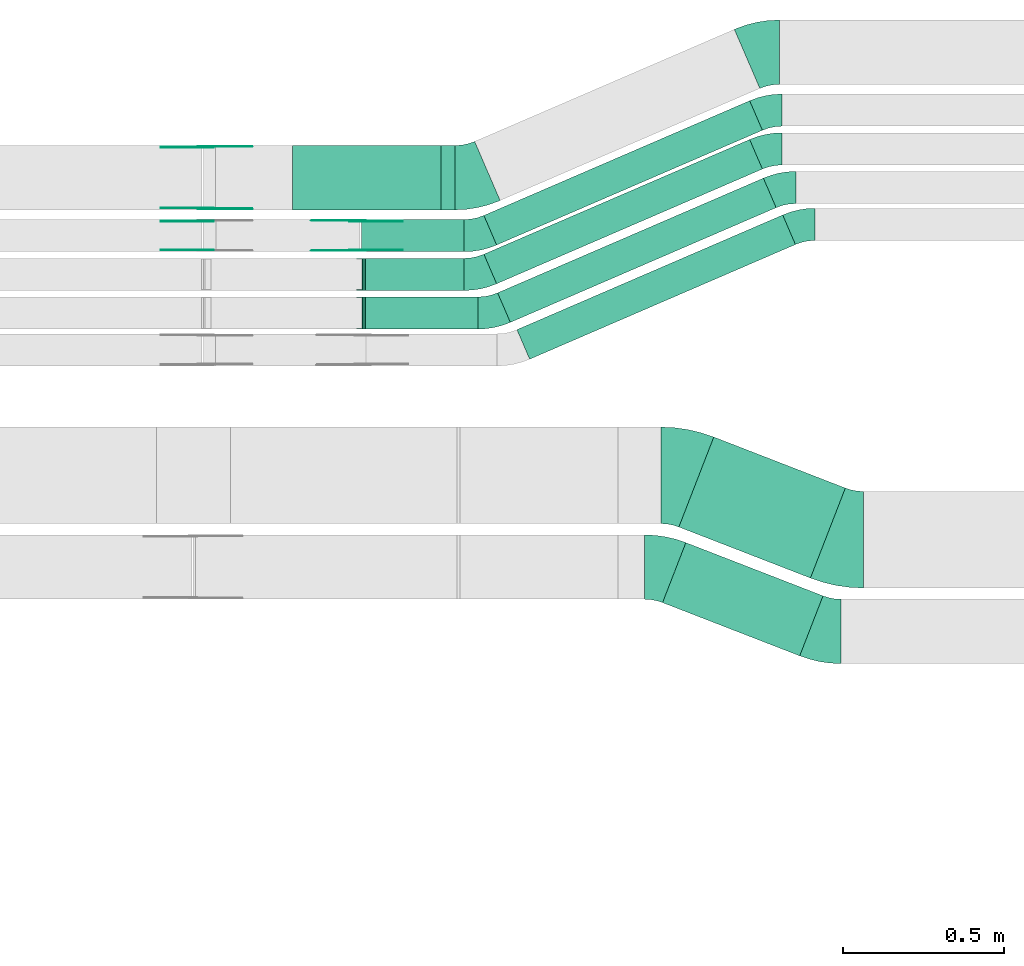
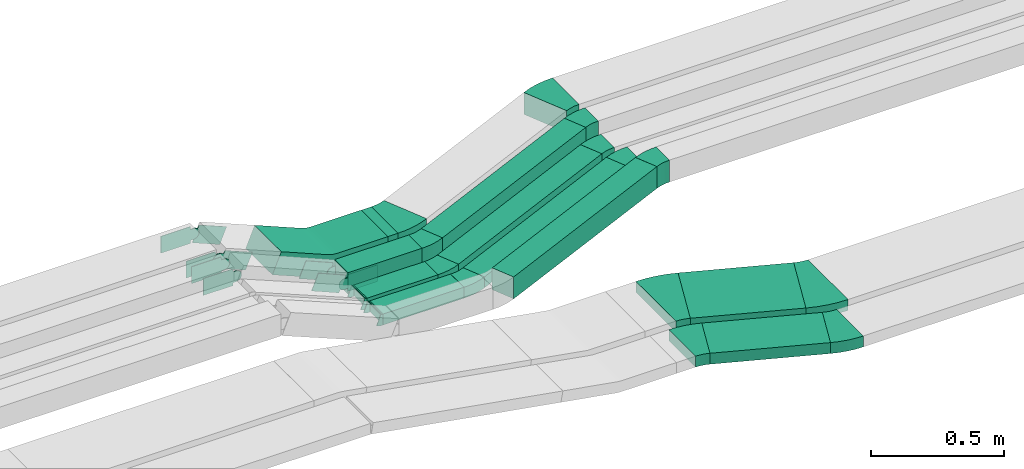
# One storey, part 16 of 28: 26 flow fittings, 10 flow segments.
"""IFC2X3 building model written with IfcOpenShell, lengths in millimetres."""

from ifc_helpers import new_model, entity, si_unit, converted_unit, derived_unit, direction, frame, frame_2d, origin, origin_2d_with_axis, place, context, subcontext, project, spatial, polyline, circle_curve, parameter, trimmed, segment, composite_curve, rectangle, outline, extrude, faceted_brep, source, transform, mapped, material, type_object, type_shapes, element, save


model = new_model("IFC2X3")

# Units and contexts
model_context = context("Model", 3, precision=0.01, world=origin(), true_north=direction((6.12303176911189e-17, 1.0)))
body_context = subcontext(model_context, "Body", "Model", "MODEL_VIEW")
ifc_project = project(units=[si_unit("LENGTHUNIT", "METRE", prefix="MILLI"), si_unit("AREAUNIT", "SQUARE_METRE"), si_unit("VOLUMEUNIT", "CUBIC_METRE"), converted_unit("PLANEANGLEUNIT", "DEGREE", entity("IfcRatioMeasure", 0.0174532925199433), si_unit("PLANEANGLEUNIT", "RADIAN"), dimensions=[0, 0, 0, 0, 0, 0, 0]), si_unit("MASSUNIT", "GRAM", prefix="KILO"), derived_unit("MASSDENSITYUNIT", [(si_unit("MASSUNIT", "GRAM", prefix="KILO"), 1), (si_unit("LENGTHUNIT", "METRE"), -3)]), derived_unit("MOMENTOFINERTIAUNIT", [(si_unit("LENGTHUNIT", "METRE"), 4)]), si_unit("TIMEUNIT", "SECOND"), si_unit("FREQUENCYUNIT", "HERTZ"), si_unit("THERMODYNAMICTEMPERATUREUNIT", "DEGREE_CELSIUS"), derived_unit("THERMALTRANSMITTANCEUNIT", [(si_unit("MASSUNIT", "GRAM", prefix="KILO"), 1), (si_unit("THERMODYNAMICTEMPERATUREUNIT", "KELVIN"), -1), (si_unit("TIMEUNIT", "SECOND"), -3)]), derived_unit("VOLUMETRICFLOWRATEUNIT", [(si_unit("LENGTHUNIT", "METRE"), 3), (si_unit("TIMEUNIT", "SECOND"), -1)]), derived_unit("MASSFLOWRATEUNIT", [(si_unit("MASSUNIT", "GRAM", prefix="KILO"), 1), (si_unit("TIMEUNIT", "SECOND"), -1)]), derived_unit("ROTATIONALFREQUENCYUNIT", [(si_unit("TIMEUNIT", "SECOND"), -1)]), si_unit("ELECTRICCURRENTUNIT", "AMPERE"), si_unit("ELECTRICVOLTAGEUNIT", "VOLT"), si_unit("POWERUNIT", "WATT"), si_unit("FORCEUNIT", "NEWTON", prefix="KILO"), si_unit("ILLUMINANCEUNIT", "LUX"), si_unit("LUMINOUSFLUXUNIT", "LUMEN"), si_unit("LUMINOUSINTENSITYUNIT", "CANDELA"), derived_unit("USERDEFINED", [(si_unit("MASSUNIT", "GRAM", prefix="KILO"), -1), (si_unit("LENGTHUNIT", "METRE"), -2), (si_unit("TIMEUNIT", "SECOND"), 3), (si_unit("LUMINOUSFLUXUNIT", "LUMEN"), 1)]), derived_unit("LINEARVELOCITYUNIT", [(si_unit("LENGTHUNIT", "METRE"), 1), (si_unit("TIMEUNIT", "SECOND"), -1)]), si_unit("PRESSUREUNIT", "PASCAL"), derived_unit("USERDEFINED", [(si_unit("LENGTHUNIT", "METRE"), -2), (si_unit("MASSUNIT", "GRAM", prefix="KILO"), 1), (si_unit("TIMEUNIT", "SECOND"), -2)]), derived_unit("LINEARFORCEUNIT", [(si_unit("MASSUNIT", "GRAM", prefix="KILO"), 1), (si_unit("LENGTHUNIT", "METRE"), 1), (si_unit("TIMEUNIT", "SECOND"), -2), (si_unit("LENGTHUNIT", "METRE"), -1)]), derived_unit("PLANARFORCEUNIT", [(si_unit("MASSUNIT", "GRAM", prefix="KILO"), 1), (si_unit("LENGTHUNIT", "METRE"), 1), (si_unit("TIMEUNIT", "SECOND"), -2), (si_unit("LENGTHUNIT", "METRE"), -2)])], contexts=[model_context])

# Site, building, storey
site_placement = place(None, origin())
site = spatial("IfcSite", under=ifc_project, at=site_placement, CompositionType="ELEMENT")
building_placement = place(site_placement, origin())
building = spatial("IfcBuilding", under=site, at=building_placement, CompositionType="ELEMENT")
storey_placement = place(building_placement, frame((0.0, 0.0, 15900.0)))
storey = spatial("IfcBuildingStorey", under=building, at=storey_placement, CompositionType="ELEMENT", Elevation=15900.0)

# Flow segments
cable_carrier_segment_type = type_object("IfcCableCarrierSegmentType", PredefinedType="CABLETRAYSEGMENT")
flow_segment_1_placement = place(storey_placement, frame((45925.0, 15609.99, 2635.0)))
element("IfcFlowSegment", 1, at=flow_segment_1_placement, inside=storey, type_object=cable_carrier_segment_type, context=body_context, shape_type="SweptSolid", body=[
    extrude(rectangle(XDim=43.6419436420277, YDim=199.999999999998, at=origin_2d_with_axis()), frame((21.82, 100.0, 0.0), z_axis=(0.0, 0.0, 1.0), x_axis=(-1.0, 0.0, 0.0)), (0.0, 0.0, 1.0), 99.9999999999989),
])
flow_segment_2_placement = place(storey_placement, frame((45677.85, 15479.99, 2635.0)))
element("IfcFlowSegment", 2, at=flow_segment_2_placement, inside=storey, type_object=cable_carrier_segment_type, context=body_context, shape_type="SweptSolid", body=[
    extrude(rectangle(XDim=319.463320328954, YDim=99.9999999999989, at=origin_2d_with_axis()), frame((159.73, 50.0, 0.0), z_axis=(0.0, 0.0, 1.0), x_axis=(-1.0, 0.0, 0.0)), (0.0, 0.0, 1.0), 100.000000000001),
])
flow_segment_3_placement = place(storey_placement, frame((45690.68, 15359.46, 2637.24)))
element("IfcFlowSegment", 3, at=flow_segment_3_placement, inside=storey, type_object=cable_carrier_segment_type, context=body_context, shape_type="SweptSolid", body=[
    extrude(rectangle(XDim=306.634255324862, YDim=99.9999999999989, at=origin_2d_with_axis()), frame((153.32, 50.0, 0.0), z_axis=(0.0, 0.0, 1.0), x_axis=(-1.0, 0.0, 0.0)), (0.0, 0.0, 1.0), 50.0000000000016),
])
flow_segment_4_placement = place(storey_placement, frame((45690.68, 15239.46, 2637.24)))
element("IfcFlowSegment", 4, at=flow_segment_4_placement, inside=storey, type_object=cable_carrier_segment_type, context=body_context, shape_type="SweptSolid", body=[
    extrude(rectangle(XDim=349.299577232627, YDim=99.9999999999989, at=origin_2d_with_axis()), frame((174.65, 50.0, 0.0)), (0.0, 0.0, 1.0), 50.0000000000016),
])
flow_segment_5_placement = place(storey_placement, frame((46664.57, 14465.87, 2650.0)))
element("IfcFlowSegment", 5, at=flow_segment_5_placement, inside=storey, type_object=cable_carrier_segment_type, context=body_context, shape_type="SweptSolid", body=[
    extrude(rectangle(XDim=438.486664288002, YDim=299.999999999994, at=origin_2d_with_axis()), frame((258.66, 219.16, 0.0), z_axis=(0.0, 0.0, 1.0), x_axis=(-0.932264171028324, 0.361778268303765, 0.0)), (0.0, 0.0, 1.0), 50.0000000000016),
])
flow_segment_6_placement = place(storey_placement, frame((46613.94, 14224.09, 2650.0)))
element("IfcFlowSegment", 6, at=flow_segment_6_placement, inside=storey, type_object=cable_carrier_segment_type, context=body_context, shape_type="SweptSolid", body=[
    extrude(rectangle(XDim=457.209687450545, YDim=200.000000000007, at=origin_2d_with_axis()), frame((249.3, 175.93, 0.0), z_axis=(0.0, 0.0, 1.0), x_axis=(0.932264171028315, -0.361778268303789, 0.0)), (0.0, 0.0, 1.0), 50.0000000000016),
])
flow_segment_7_placement = place(storey_placement, frame((46058.67, 15500.86, 2635.0)))
element("IfcFlowSegment", 7, at=flow_segment_7_placement, inside=storey, type_object=cable_carrier_segment_type, context=body_context, shape_type="SweptSolid", body=[
    extrude(rectangle(XDim=899.544928031288, YDim=100.000000000003, at=origin_2d_with_axis()), frame((432.77, 224.14, 0.0), z_axis=(0.0, 0.0, 1.0), x_axis=(-0.918134666973487, -0.396268511619942, 0.0)), (0.0, 0.0, 1.0), 99.9999999999989),
])
flow_segment_8_placement = place(storey_placement, frame((46058.67, 15380.32, 2637.24)))
element("IfcFlowSegment", 8, at=flow_segment_8_placement, inside=storey, type_object=cable_carrier_segment_type, context=body_context, shape_type="SweptSolid", body=[
    extrude(rectangle(XDim=899.544928031294, YDim=99.999999999988, at=origin_2d_with_axis()), frame((432.77, 224.14, 0.0), z_axis=(0.0, 0.0, 1.0), x_axis=(-0.9181346669735, -0.396268511619913, 0.0)), (0.0, 0.0, 1.0), 50.0000000000016),
])
flow_segment_9_placement = place(storey_placement, frame((46101.34, 15260.32, 2637.24)))
element("IfcFlowSegment", 9, at=flow_segment_9_placement, inside=storey, type_object=cable_carrier_segment_type, context=body_context, shape_type="SweptSolid", body=[
    extrude(rectangle(XDim=899.544928031396, YDim=99.999999999988, at=origin_2d_with_axis()), frame((432.77, 224.14, 0.0), z_axis=(0.0, 0.0, 1.0), x_axis=(-0.918134666973501, -0.396268511619909, 0.0)), (0.0, 0.0, 1.0), 50.0000000000016),
])
flow_segment_10_placement = place(storey_placement, frame((46161.34, 15145.86, 2634.95)))
element("IfcFlowSegment", 10, at=flow_segment_10_placement, inside=storey, type_object=cable_carrier_segment_type, context=body_context, shape_type="SweptSolid", body=[
    extrude(rectangle(XDim=899.544928031165, YDim=100.000000000003, at=origin_2d_with_axis()), frame((432.77, 224.14, 0.0), z_axis=(0.0, 0.0, 1.0), x_axis=(-0.918134666973488, -0.396268511619941, 0.0)), (0.0, 0.0, 1.0), 99.9999999999989),
])

# Flow fittings
ifc_material_1 = material()
cable_carrier_fitting_type_1 = type_object("IfcCableCarrierFittingType", PredefinedType="NOTDEFINED", material=ifc_material_1)
shared_shape_1 = source(origin(), body_context, "Body", "Brep", [
    faceted_brep([(-9.86, 25.0, 50.0), (-9.86, 25.0, -50.0), (-9.86, -25.0, -50.0), (-9.86, -25.0, -47.46), (-9.86, 22.46, -47.46), (-9.86, 22.46, 47.46), (-9.86, -25.0, 47.46), (-9.86, -25.0, 50.0), (-0.37, 26.87, 50.0), (18.62, -19.38, 50.0), (18.62, -19.38, 47.46), (0.6, 24.52, 47.46), (0.6, 24.52, -47.46), (18.62, -19.38, -47.46), (18.62, -19.38, -50.0), (-0.37, 26.87, -50.0), (-4.93, 25.0, 50.0), (-4.93, 25.0, -50.0), (4.93, -25.0, -50.0), (4.93, -25.0, -47.46), (-4.43, 22.46, -47.46), (-4.43, 22.46, 47.46), (4.93, -25.0, 47.46), (4.93, -25.0, 50.0)], [[[0, 1, 2, 3, 4, 5, 6, 7]], [[8, 9, 10, 11, 12, 13, 14, 15]], [[1, 0, 16, 17]], [[2, 1, 17, 15, 14, 18]], [[3, 2, 18, 19]], [[4, 3, 19, 13, 12, 20]], [[5, 4, 20, 21]], [[6, 5, 21, 11, 10, 22]], [[7, 6, 22, 23]], [[0, 7, 23, 9, 8, 16]], [[17, 16, 8, 15]], [[19, 18, 14, 13]], [[21, 20, 12, 11]], [[23, 22, 10, 9]]]),
])
type_shapes(cable_carrier_fitting_type_1, [shared_shape_1])
for number, where, z_axis, x_axis in (
    (11, (45680.82, 15409.46, 2662.24), (0.0, 1.0, 0.0), (-1.0, 0.0, 0.0)),
    (12, (45680.82, 15289.46, 2662.24), (0.0, -1.0, 0.0), (0.925113085294543, 0.0, -0.379691689949639)),
):
    element("IfcFlowFitting", number, at=place(storey_placement, frame(where, z_axis=z_axis, x_axis=x_axis)), inside=storey, type_object=cable_carrier_fitting_type_1, material=ifc_material_1, context=body_context, shape_type="MappedRepresentation", body=[
        mapped(shared_shape_1, transform((0.0, 0.0, 0.0), scale=1.0)),
    ])
ifc_material_2 = material(Name="G")
cable_carrier_fitting_type_2 = type_object("IfcCableCarrierFittingType", PredefinedType="NOTDEFINED", material=ifc_material_2)
shared_shape_2 = source(origin(), body_context, "Body", "SweptSolid", [
    extrude(outline(composite_curve([segment(trimmed(circle_curve(frame_2d((-41.47, 0.0), x_axis=(1.0, 0.0)), 25.0), [parameter(90.0000000000007)], [parameter(270.0)], True, "PARAMETER"), True, "CONTINUOUS"), segment(polyline([(-41.47, -25.0), (-29.97, -25.0)]), True, "CONTINUOUS"), segment(polyline([(-29.97, -25.0), (-28.1, -38.5)]), True, "CONTINUOUS"), segment(polyline([(-28.1, -38.5), (99.53, -38.5)]), True, "CONTINUOUS"), segment(polyline([(99.53, -38.5), (99.53, 38.5)]), True, "CONTINUOUS"), segment(polyline([(99.53, 38.5), (-28.1, 38.5)]), True, "CONTINUOUS"), segment(polyline([(-28.1, 38.5), (-29.97, 25.0)]), True, "CONTINUOUS"), segment(polyline([(-29.97, 25.0), (-41.47, 25.0)]), True, "CONTINUOUS")], self_intersect=False)), frame((41.47, 0.0, 0.0), z_axis=(0.0, 0.0, -1.0), x_axis=(1.0, 0.0, 0.0)), (0.0, 0.0, -1.0), 2.0),
])
type_shapes(cable_carrier_fitting_type_2, [shared_shape_2])
flow_fitting_1_placement = place(storey_placement, frame((45195.0, 15486.53, 2885.0), z_axis=(0.0, -1.0, 0.0), x_axis=(-1.0, 0.0, 0.0)))
element("IfcFlowFitting", 13, at=flow_fitting_1_placement, inside=storey, type_object=cable_carrier_fitting_type_2, material=ifc_material_2, context=body_context, shape_type="MappedRepresentation", body=[
    mapped(shared_shape_2, transform((0.0, 0.0, 0.0), scale=1.0)),
])
cable_carrier_fitting_type_3 = type_object("IfcCableCarrierFittingType", PredefinedType="NOTDEFINED", material=ifc_material_2)
type_shapes(cable_carrier_fitting_type_3, [shared_shape_2])
flow_fitting_2_placement = place(storey_placement, frame((45665.86, 15575.45, 2685.0), z_axis=(0.0, 1.0, 0.0), x_axis=(-0.920411299750602, 0.0, 0.390951453880668)))
element("IfcFlowFitting", 14, at=flow_fitting_2_placement, inside=storey, type_object=cable_carrier_fitting_type_3, material=ifc_material_2, context=body_context, shape_type="MappedRepresentation", body=[
    mapped(shared_shape_2, transform((0.0, 0.0, 0.0), scale=1.0)),
])
flow_fitting_3_placement = place(storey_placement, frame((45665.86, 15486.53, 2685.0), z_axis=(0.0, -1.0, 0.0), x_axis=(1.0, 0.0, 0.0)))
element("IfcFlowFitting", 15, at=flow_fitting_3_placement, inside=storey, type_object=cable_carrier_fitting_type_2, material=ifc_material_2, context=body_context, shape_type="MappedRepresentation", body=[
    mapped(shared_shape_2, transform((0.0, 0.0, 0.0), scale=1.0)),
])
flow_fitting_4_placement = place(storey_placement, frame((45195.0, 15805.45, 2885.0), z_axis=(0.0, 1.0, 0.0), x_axis=(0.92307692307691, 0.0, -0.384615384615415)))
element("IfcFlowFitting", 16, at=flow_fitting_4_placement, inside=storey, type_object=cable_carrier_fitting_type_3, material=ifc_material_2, context=body_context, shape_type="MappedRepresentation", body=[
    mapped(shared_shape_2, transform((0.0, 0.0, 0.0), scale=1.0)),
])
flow_fitting_5_placement = place(storey_placement, frame((45195.0, 15616.53, 2885.0), z_axis=(0.0, -1.0, 0.0), x_axis=(-1.0, 0.0, 0.0)))
element("IfcFlowFitting", 17, at=flow_fitting_5_placement, inside=storey, type_object=cable_carrier_fitting_type_2, material=ifc_material_2, context=body_context, shape_type="MappedRepresentation", body=[
    mapped(shared_shape_2, transform((0.0, 0.0, 0.0), scale=1.0)),
])
cable_carrier_fitting_type_4 = type_object("IfcCableCarrierFittingType", PredefinedType="NOTDEFINED", material=ifc_material_2)
shared_shape_3 = source(origin(), body_context, "Body", "SweptSolid", [
    extrude(outline(composite_curve([segment(trimmed(circle_curve(frame_2d((-41.47, 0.0), x_axis=(1.0, 0.0)), 25.0), [parameter(90.0000000000007)], [parameter(270.0)], True, "PARAMETER"), True, "CONTINUOUS"), segment(polyline([(-41.47, -25.0), (-29.97, -25.0)]), True, "CONTINUOUS"), segment(polyline([(-29.97, -25.0), (-28.1, -38.5)]), True, "CONTINUOUS"), segment(polyline([(-28.1, -38.5), (99.53, -38.5)]), True, "CONTINUOUS"), segment(polyline([(99.53, -38.5), (99.53, 38.5)]), True, "CONTINUOUS"), segment(polyline([(99.53, 38.5), (-28.1, 38.5)]), True, "CONTINUOUS"), segment(polyline([(-28.1, 38.5), (-29.97, 25.0)]), True, "CONTINUOUS"), segment(polyline([(-29.97, 25.0), (-41.47, 25.0)]), True, "CONTINUOUS")], self_intersect=False)), frame((41.47, 0.0, 0.0)), (0.0, 0.0, 1.0), 2.0),
])
type_shapes(cable_carrier_fitting_type_4, [shared_shape_3])
flow_fitting_6_placement = place(storey_placement, frame((45195.0, 15573.45, 2885.0), z_axis=(0.0, 1.0, 0.0), x_axis=(-1.0, 0.0, 0.0)))
element("IfcFlowFitting", 18, at=flow_fitting_6_placement, inside=storey, type_object=cable_carrier_fitting_type_4, material=ifc_material_2, context=body_context, shape_type="MappedRepresentation", body=[
    mapped(shared_shape_3, transform((0.0, 0.0, 0.0), scale=1.0)),
])
cable_carrier_fitting_type_5 = type_object("IfcCableCarrierFittingType", PredefinedType="NOTDEFINED", material=ifc_material_2)
type_shapes(cable_carrier_fitting_type_5, [shared_shape_3])
flow_fitting_7_placement = place(storey_placement, frame((45665.86, 15484.53, 2685.0), z_axis=(0.0, -1.0, 0.0), x_axis=(-0.920411299750602, 0.0, 0.390951453880668)))
element("IfcFlowFitting", 19, at=flow_fitting_7_placement, inside=storey, type_object=cable_carrier_fitting_type_5, material=ifc_material_2, context=body_context, shape_type="MappedRepresentation", body=[
    mapped(shared_shape_3, transform((0.0, 0.0, 0.0), scale=1.0)),
])
flow_fitting_8_placement = place(storey_placement, frame((45665.86, 15573.45, 2685.0), z_axis=(0.0, 1.0, 0.0), x_axis=(1.0, 0.0, 0.0)))
element("IfcFlowFitting", 20, at=flow_fitting_8_placement, inside=storey, type_object=cable_carrier_fitting_type_4, material=ifc_material_2, context=body_context, shape_type="MappedRepresentation", body=[
    mapped(shared_shape_3, transform((0.0, 0.0, 0.0), scale=1.0)),
])
flow_fitting_9_placement = place(storey_placement, frame((45195.0, 15614.53, 2885.0), z_axis=(0.0, -1.0, 0.0), x_axis=(0.92307692307691, 0.0, -0.384615384615415)))
element("IfcFlowFitting", 21, at=flow_fitting_9_placement, inside=storey, type_object=cable_carrier_fitting_type_5, material=ifc_material_2, context=body_context, shape_type="MappedRepresentation", body=[
    mapped(shared_shape_3, transform((0.0, 0.0, 0.0), scale=1.0)),
])
flow_fitting_10_placement = place(storey_placement, frame((45195.0, 15803.45, 2885.0), z_axis=(0.0, 1.0, 0.0), x_axis=(-1.0, 0.0, 0.0)))
element("IfcFlowFitting", 22, at=flow_fitting_10_placement, inside=storey, type_object=cable_carrier_fitting_type_4, material=ifc_material_2, context=body_context, shape_type="MappedRepresentation", body=[
    mapped(shared_shape_3, transform((0.0, 0.0, 0.0), scale=1.0)),
])
cable_carrier_fitting_type_6 = type_object("IfcCableCarrierFittingType", Name="470_DKC_S5_CS 90 internal vertical angle:-", PredefinedType="NOTDEFINED", material=ifc_material_1)
shared_shape_4 = source(origin(), body_context, "Body", "SweptSolid", [
    extrude(outline(composite_curve([segment(polyline([(-244.56, -77.21), (-27.56, -77.21)]), True, "CONTINUOUS"), segment(trimmed(circle_curve(frame_2d((-27.56, 137.79), x_axis=(0.0, -1.0)), 214.999999999999), [parameter(0.0)], [parameter(22.6198649480428)], True, "PARAMETER"), True, "CONTINUOUS"), segment(polyline([(55.13, -60.67), (255.44, 22.79)]), True, "CONTINUOUS"), segment(polyline([(255.44, 22.79), (216.98, 115.1)]), True, "CONTINUOUS"), segment(polyline([(216.98, 115.1), (16.67, 31.63)]), True, "CONTINUOUS"), segment(trimmed(circle_curve(frame_2d((-27.56, 137.79), x_axis=(0.0, -1.0)), 114.999999999999), [parameter(0.0)], [parameter(22.6198649480428)], True, "PARAMETER"), False, "CONTINUOUS"), segment(polyline([(-27.56, 22.79), (-244.56, 22.79)]), True, "CONTINUOUS"), segment(polyline([(-244.56, 22.79), (-244.56, -77.21)]), True, "CONTINUOUS")], self_intersect=False)), frame((-5.44, 27.21, -100.0)), (0.0, 0.0, 1.0), 200.0),
])
type_shapes(cable_carrier_fitting_type_6, [shared_shape_4])
flow_fitting_11_placement = place(storey_placement, frame((45675.0, 15709.99, 2685.0), z_axis=(0.0, 1.0, 0.0), x_axis=(-1.0, 0.0, 0.0)))
element("IfcFlowFitting", 23, at=flow_fitting_11_placement, inside=storey, type_object=cable_carrier_fitting_type_6, material=ifc_material_1, Name="470_DKC_S5_CS 90 internal vertical angle:-", ObjectType="470_DKC_S5_CS 90 internal vertical angle:-", context=body_context, shape_type="MappedRepresentation", body=[
    mapped(shared_shape_4, transform((0.0, 0.0, 0.0), scale=1.0)),
])
cable_carrier_fitting_type_7 = type_object("IfcCableCarrierFittingType", Name="470_DKC_S5_Variable Angle Elbow 0-45:-", PredefinedType="NOTDEFINED", material=ifc_material_1)
shared_shape_5 = source(origin(), body_context, "Body", "SweptSolid", [
    extrude(outline(composite_curve([segment(polyline([(-55.25, -160.25), (-54.25, -160.25)]), True, "CONTINUOUS"), segment(trimmed(circle_curve(frame_2d((-54.25, 289.75), x_axis=(0.0, -1.0)), 450.0), [parameter(0.0)], [parameter(21.2094457966376)], True, "PARAMETER"), True, "CONTINUOUS"), segment(polyline([(108.55, -129.77), (109.48, -129.41)]), True, "CONTINUOUS"), segment(polyline([(109.48, -129.41), (0.95, 150.27)]), True, "CONTINUOUS"), segment(polyline([(0.95, 150.27), (0.02, 149.91)]), True, "CONTINUOUS"), segment(trimmed(circle_curve(frame_2d((-54.25, 289.75), x_axis=(0.0, -1.0)), 150.0), [parameter(0.0)], [parameter(21.2094457966376)], True, "PARAMETER"), False, "CONTINUOUS"), segment(polyline([(-54.25, 139.75), (-55.25, 139.75)]), True, "CONTINUOUS"), segment(polyline([(-55.25, 139.75), (-55.25, -160.25)]), True, "CONTINUOUS")], self_intersect=False)), frame((-1.92, 10.25, -25.0)), (0.0, 0.0, 1.0), 49.9999999999992),
])
type_shapes(cable_carrier_fitting_type_7, [shared_shape_5])
for number, where, z_axis, x_axis, name in (
    (24, (47180.92, 14585.03, 2675.0), (0.0, 0.0, 1.0), (0.932264171028328, -0.361778268303755, 0.0), "470_DKC_S5_Variable Angle Elbow 0-45:-"),
    (25, (46665.54, 14785.03, 2675.0), (0.0, 0.0, 1.0), (-0.932264171028324, 0.361778268303765, 0.0), "470_DKC_S5_Variable Angle Elbow 0-45:-"),
):
    element("IfcFlowFitting", number, at=place(storey_placement, frame(where, z_axis=z_axis, x_axis=x_axis)), inside=storey, type_object=cable_carrier_fitting_type_7, material=ifc_material_1, Name=name, ObjectType="470_DKC_S5_Variable Angle Elbow 0-45:-", context=body_context, shape_type="MappedRepresentation", body=[
        mapped(shared_shape_5, transform((0.0, 0.0, 0.0), scale=1.0)),
    ])
cable_carrier_fitting_type_8 = type_object("IfcCableCarrierFittingType", Name="470_DKC_S5_Variable Angle Elbow 0-45:-", PredefinedType="NOTDEFINED", material=ifc_material_1)
shared_shape_6 = source(origin(), body_context, "Body", "SweptSolid", [
    extrude(outline(composite_curve([segment(polyline([(-46.21, -108.56), (-45.21, -108.56)]), True, "CONTINUOUS"), segment(trimmed(circle_curve(frame_2d((-45.21, 241.44), x_axis=(0.0, -1.0)), 350.0), [parameter(0.0)], [parameter(21.2094457966389)], True, "PARAMETER"), True, "CONTINUOUS"), segment(polyline([(81.42, -84.85), (82.35, -84.49)]), True, "CONTINUOUS"), segment(polyline([(82.35, -84.49), (9.99, 101.96)]), True, "CONTINUOUS"), segment(polyline([(9.99, 101.96), (9.06, 101.6)]), True, "CONTINUOUS"), segment(trimmed(circle_curve(frame_2d((-45.21, 241.44), x_axis=(0.0, -1.0)), 150.0), [parameter(0.0)], [parameter(21.2094457966389)], True, "PARAMETER"), False, "CONTINUOUS"), segment(polyline([(-45.21, 91.44), (-46.21, 91.44)]), True, "CONTINUOUS"), segment(polyline([(-46.21, 91.44), (-46.21, -108.56)]), True, "CONTINUOUS")], self_intersect=False)), frame((-1.6, 8.56, -25.0)), (0.0, 0.0, 1.0), 50.0000000000005),
])
type_shapes(cable_carrier_fitting_type_8, [shared_shape_6])
for number, where, z_axis, x_axis, name in (
    (26, (46605.54, 14500.03, 2675.0), (0.0, 0.0, 1.0), (-0.932264171028324, 0.361778268303765, 0.0), "470_DKC_S5_Variable Angle Elbow 0-45:-"),
    (27, (47120.92, 14300.03, 2675.0), (0.0, 0.0, 1.0), (0.932264171028321, -0.361778268303775, 0.0), "470_DKC_S5_Variable Angle Elbow 0-45:-"),
):
    element("IfcFlowFitting", number, at=place(storey_placement, frame(where, z_axis=z_axis, x_axis=x_axis)), inside=storey, type_object=cable_carrier_fitting_type_8, material=ifc_material_1, Name=name, ObjectType="470_DKC_S5_Variable Angle Elbow 0-45:-", context=body_context, shape_type="MappedRepresentation", body=[
        mapped(shared_shape_6, transform((0.0, 0.0, 0.0), scale=1.0)),
    ])
cable_carrier_fitting_type_9 = type_object("IfcCableCarrierFittingType", Name="470_DKC_S5_Variable Angle Elbow 0-45:-", PredefinedType="NOTDEFINED", material=ifc_material_1)
shared_shape_7 = source(origin(), body_context, "Body", "SweptSolid", [
    extrude(outline(composite_curve([segment(polyline([(-50.51, -110.33), (-49.51, -110.33)]), True, "CONTINUOUS"), segment(trimmed(circle_curve(frame_2d((-49.51, 239.67), x_axis=(0.0, -1.0)), 350.0), [parameter(0.0)], [parameter(23.3451113937058)], True, "PARAMETER"), True, "CONTINUOUS"), segment(polyline([(89.18, -81.68), (90.1, -81.28)]), True, "CONTINUOUS"), segment(polyline([(90.1, -81.28), (10.85, 102.34)]), True, "CONTINUOUS"), segment(polyline([(10.85, 102.34), (9.93, 101.95)]), True, "CONTINUOUS"), segment(trimmed(circle_curve(frame_2d((-49.51, 239.67), x_axis=(0.0, -1.0)), 150.0), [parameter(0.0)], [parameter(23.3451113937058)], True, "PARAMETER"), False, "CONTINUOUS"), segment(polyline([(-49.51, 89.67), (-50.51, 89.67)]), True, "CONTINUOUS"), segment(polyline([(-50.51, 89.67), (-50.51, -110.33)]), True, "CONTINUOUS")], self_intersect=False)), frame((-2.13, 10.33, -50.0)), (0.0, 0.0, 1.0), 100.0),
])
type_shapes(cable_carrier_fitting_type_9, [shared_shape_7])
flow_fitting_12_placement = place(storey_placement, frame((46924.9, 16099.99, 2685.0), z_axis=(0.0, 0.0, 1.0), x_axis=(-1.0, 0.0, 0.0)))
element("IfcFlowFitting", 28, at=flow_fitting_12_placement, inside=storey, type_object=cable_carrier_fitting_type_9, material=ifc_material_1, Name="470_DKC_S5_Variable Angle Elbow 0-45:-", ObjectType="470_DKC_S5_Variable Angle Elbow 0-45:-", context=body_context, shape_type="MappedRepresentation", body=[
    mapped(shared_shape_7, transform((0.0, 0.0, 0.0), scale=1.0)),
])
flow_fitting_13_placement = place(storey_placement, frame((46021.29, 15709.99, 2685.0)))
element("IfcFlowFitting", 29, at=flow_fitting_13_placement, inside=storey, type_object=cable_carrier_fitting_type_9, material=ifc_material_1, Name="470_DKC_S5_Variable Angle Elbow 0-45:-", ObjectType="470_DKC_S5_Variable Angle Elbow 0-45:-", context=body_context, shape_type="MappedRepresentation", body=[
    mapped(shared_shape_7, transform((0.0, 0.0, 0.0), scale=1.0)),
])
cable_carrier_fitting_type_10 = type_object("IfcCableCarrierFittingType", Name="470_DKC_S5_Variable Angle Elbow 0-45:-", PredefinedType="NOTDEFINED", material=ifc_material_1)
shared_shape_8 = source(origin(), body_context, "Body", "SweptSolid", [
    extrude(outline(composite_curve([segment(polyline([(-40.61, -58.29), (-39.61, -58.29)]), True, "CONTINUOUS"), segment(trimmed(circle_curve(frame_2d((-39.61, 191.71), x_axis=(0.0, -1.0)), 250.0), [parameter(0.0)], [parameter(23.3451113937074)], True, "PARAMETER"), True, "CONTINUOUS"), segment(polyline([(59.46, -37.82), (60.38, -37.42)]), True, "CONTINUOUS"), segment(polyline([(60.38, -37.42), (20.75, 54.39)]), True, "CONTINUOUS"), segment(polyline([(20.75, 54.39), (19.83, 53.99)]), True, "CONTINUOUS"), segment(trimmed(circle_curve(frame_2d((-39.61, 191.71), x_axis=(0.0, -1.0)), 150.0), [parameter(0.0)], [parameter(23.3451113937074)], True, "PARAMETER"), False, "CONTINUOUS"), segment(polyline([(-39.61, 41.71), (-40.61, 41.71)]), True, "CONTINUOUS"), segment(polyline([(-40.61, 41.71), (-40.61, -58.29)]), True, "CONTINUOUS")], self_intersect=False)), frame((-1.71, 8.29, -50.0)), (0.0, 0.0, 1.0), 100.0),
])
type_shapes(cable_carrier_fitting_type_10, [shared_shape_8])
flow_fitting_14_placement = place(storey_placement, frame((46943.24, 15919.99, 2685.0), z_axis=(0.0, 0.0, 1.0), x_axis=(-1.0, 0.0, 0.0)))
element("IfcFlowFitting", 30, at=flow_fitting_14_placement, inside=storey, type_object=cable_carrier_fitting_type_10, material=ifc_material_1, Name="470_DKC_S5_Variable Angle Elbow 0-45:-", ObjectType="470_DKC_S5_Variable Angle Elbow 0-45:-", context=body_context, shape_type="MappedRepresentation", body=[
    mapped(shared_shape_8, transform((0.0, 0.0, 0.0), scale=1.0)),
])
flow_fitting_15_placement = place(storey_placement, frame((46039.63, 15529.99, 2685.0)))
element("IfcFlowFitting", 31, at=flow_fitting_15_placement, inside=storey, type_object=cable_carrier_fitting_type_10, material=ifc_material_1, Name="470_DKC_S5_Variable Angle Elbow 0-45:-", ObjectType="470_DKC_S5_Variable Angle Elbow 0-45:-", context=body_context, shape_type="MappedRepresentation", body=[
    mapped(shared_shape_8, transform((0.0, 0.0, 0.0), scale=1.0)),
])
flow_fitting_16_placement = place(storey_placement, frame((47045.91, 15564.99, 2684.95), z_axis=(0.0, 0.0, 1.0), x_axis=(-1.0, 0.0, 0.0)))
element("IfcFlowFitting", 32, at=flow_fitting_16_placement, inside=storey, type_object=cable_carrier_fitting_type_10, material=ifc_material_1, Name="470_DKC_S5_Variable Angle Elbow 0-45:-", ObjectType="470_DKC_S5_Variable Angle Elbow 0-45:-", context=body_context, shape_type="MappedRepresentation", body=[
    mapped(shared_shape_8, transform((0.0, 0.0, 0.0), scale=1.0)),
])
cable_carrier_fitting_type_11 = type_object("IfcCableCarrierFittingType", Name="470_DKC_S5_Variable Angle Elbow 0-45:-", PredefinedType="NOTDEFINED", material=ifc_material_1)
shared_shape_9 = source(origin(), body_context, "Body", "SweptSolid", [
    extrude(outline(composite_curve([segment(polyline([(-40.61, -58.29), (-39.61, -58.29)]), True, "CONTINUOUS"), segment(trimmed(circle_curve(frame_2d((-39.61, 191.71), x_axis=(0.0, -1.0)), 250.0), [parameter(0.0)], [parameter(23.3451113937073)], True, "PARAMETER"), True, "CONTINUOUS"), segment(polyline([(59.46, -37.82), (60.38, -37.42)]), True, "CONTINUOUS"), segment(polyline([(60.38, -37.42), (20.75, 54.39)]), True, "CONTINUOUS"), segment(polyline([(20.75, 54.39), (19.83, 53.99)]), True, "CONTINUOUS"), segment(trimmed(circle_curve(frame_2d((-39.61, 191.71), x_axis=(0.0, -1.0)), 150.0), [parameter(0.0)], [parameter(23.3451113937073)], True, "PARAMETER"), False, "CONTINUOUS"), segment(polyline([(-39.61, 41.71), (-40.61, 41.71)]), True, "CONTINUOUS"), segment(polyline([(-40.61, 41.71), (-40.61, -58.29)]), True, "CONTINUOUS")], self_intersect=False)), frame((-1.71, 8.29, -25.0)), (0.0, 0.0, 1.0), 50.0000000000001),
])
type_shapes(cable_carrier_fitting_type_11, [shared_shape_9])
flow_fitting_17_placement = place(storey_placement, frame((46943.24, 15799.46, 2662.24), z_axis=(0.0, 0.0, 1.0), x_axis=(-1.0, 0.0, 0.0)))
element("IfcFlowFitting", 33, at=flow_fitting_17_placement, inside=storey, type_object=cable_carrier_fitting_type_11, material=ifc_material_1, Name="470_DKC_S5_Variable Angle Elbow 0-45:-", ObjectType="470_DKC_S5_Variable Angle Elbow 0-45:-", context=body_context, shape_type="MappedRepresentation", body=[
    mapped(shared_shape_9, transform((0.0, 0.0, 0.0), scale=1.0)),
])
flow_fitting_18_placement = place(storey_placement, frame((46039.63, 15409.46, 2662.24)))
element("IfcFlowFitting", 34, at=flow_fitting_18_placement, inside=storey, type_object=cable_carrier_fitting_type_11, material=ifc_material_1, Name="470_DKC_S5_Variable Angle Elbow 0-45:-", ObjectType="470_DKC_S5_Variable Angle Elbow 0-45:-", context=body_context, shape_type="MappedRepresentation", body=[
    mapped(shared_shape_9, transform((0.0, 0.0, 0.0), scale=1.0)),
])
flow_fitting_19_placement = place(storey_placement, frame((46985.91, 15679.46, 2662.24), z_axis=(0.0, 0.0, 1.0), x_axis=(-1.0, 0.0, 0.0)))
element("IfcFlowFitting", 35, at=flow_fitting_19_placement, inside=storey, type_object=cable_carrier_fitting_type_11, material=ifc_material_1, Name="470_DKC_S5_Variable Angle Elbow 0-45:-", ObjectType="470_DKC_S5_Variable Angle Elbow 0-45:-", context=body_context, shape_type="MappedRepresentation", body=[
    mapped(shared_shape_9, transform((0.0, 0.0, 0.0), scale=1.0)),
])
flow_fitting_20_placement = place(storey_placement, frame((46082.3, 15289.46, 2662.24)))
element("IfcFlowFitting", 36, at=flow_fitting_20_placement, inside=storey, type_object=cable_carrier_fitting_type_11, material=ifc_material_1, Name="470_DKC_S5_Variable Angle Elbow 0-45:-", ObjectType="470_DKC_S5_Variable Angle Elbow 0-45:-", context=body_context, shape_type="MappedRepresentation", body=[
    mapped(shared_shape_9, transform((0.0, 0.0, 0.0), scale=1.0)),
])

save(model, "model.ifc")
